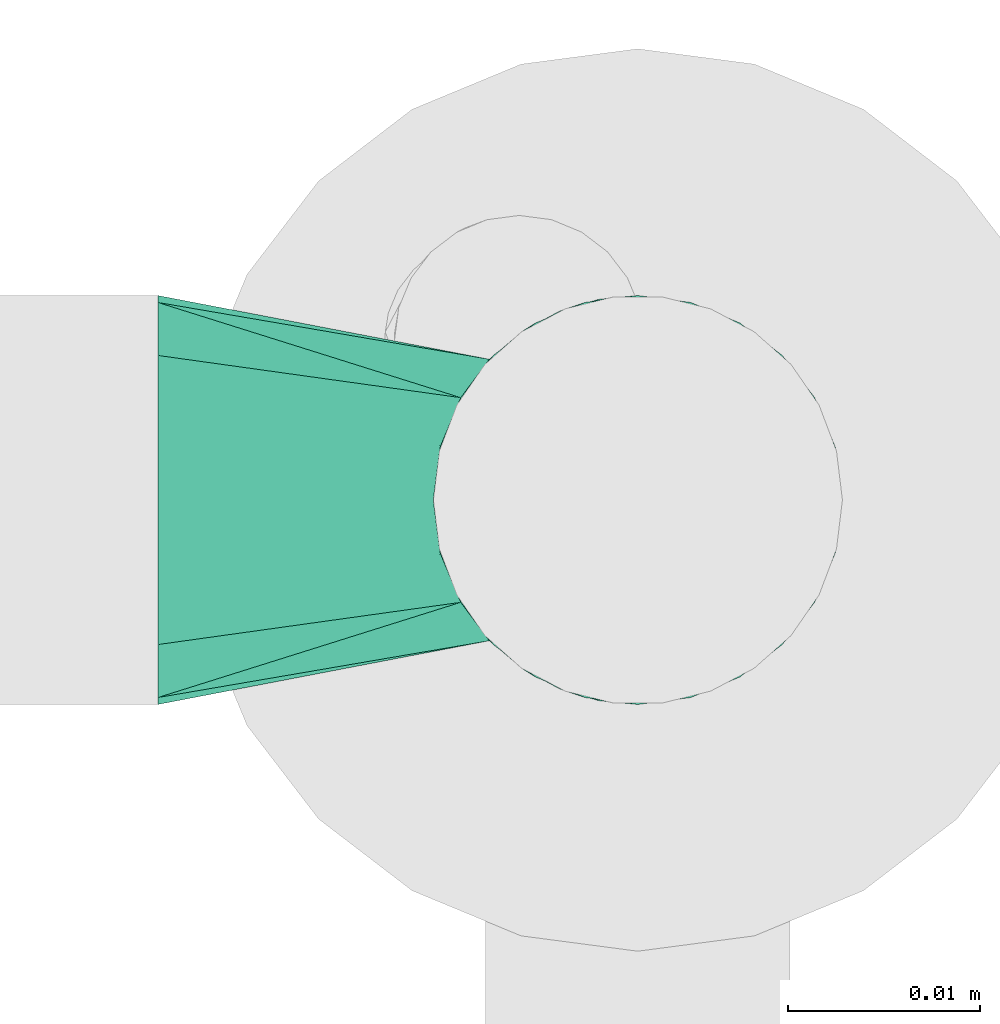
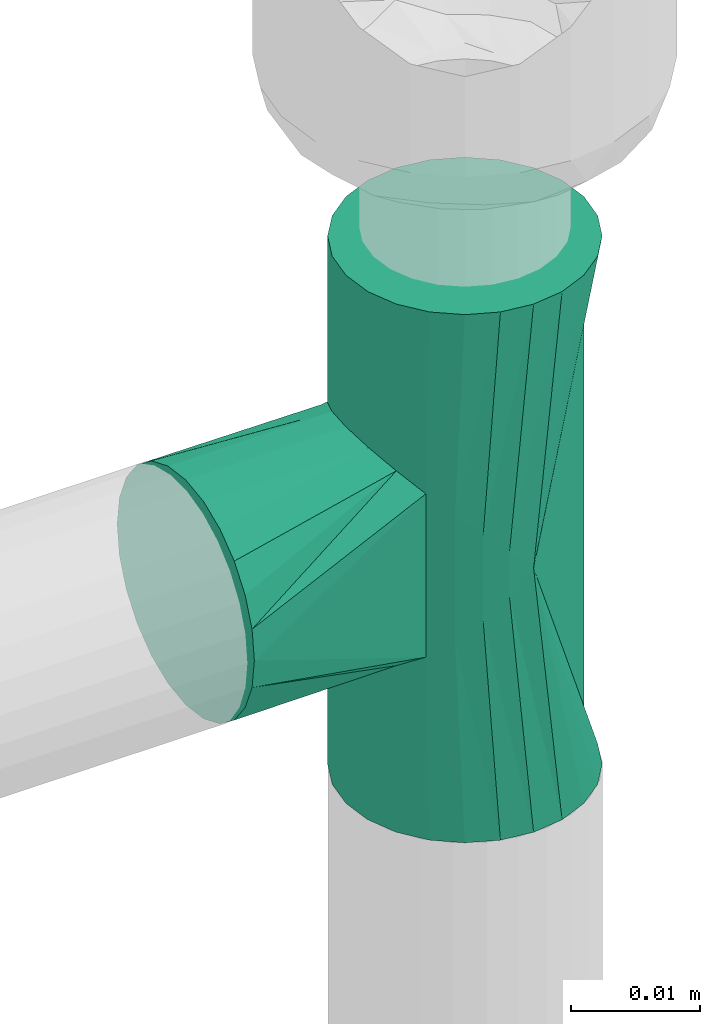
# One storey, part 819 of 827: 1 flow fitting.
"""IFC2X3 building model written with IfcOpenShell, lengths in millimetres."""

from ifc_helpers import new_model, entity, si_unit, converted_unit, derived_unit, direction, frame, origin, place, context, subcontext, project, spatial, faceted_brep, source, transform, mapped, material, type_object, type_shapes, element, save


model = new_model("IFC2X3")

# Units and contexts
model_context = context("Model", 3, precision=0.01, world=origin(), true_north=direction((6.12303176911189e-17, 1.0)))
body_context = subcontext(model_context, "Body", "Model", "MODEL_VIEW")
ifc_project = project(units=[si_unit("LENGTHUNIT", "METRE", prefix="MILLI"), si_unit("AREAUNIT", "SQUARE_METRE"), si_unit("VOLUMEUNIT", "CUBIC_METRE"), converted_unit("PLANEANGLEUNIT", "DEGREE", entity("IfcRatioMeasure", 0.0174532925199433), si_unit("PLANEANGLEUNIT", "RADIAN"), dimensions=[0, 0, 0, 0, 0, 0, 0]), si_unit("MASSUNIT", "GRAM", prefix="KILO"), derived_unit("MASSDENSITYUNIT", [(si_unit("MASSUNIT", "GRAM", prefix="KILO"), 1), (si_unit("LENGTHUNIT", "METRE"), -3)]), derived_unit("MOMENTOFINERTIAUNIT", [(si_unit("LENGTHUNIT", "METRE"), 4)]), si_unit("TIMEUNIT", "SECOND"), si_unit("FREQUENCYUNIT", "HERTZ"), si_unit("THERMODYNAMICTEMPERATUREUNIT", "DEGREE_CELSIUS"), derived_unit("THERMALTRANSMITTANCEUNIT", [(si_unit("MASSUNIT", "GRAM", prefix="KILO"), 1), (si_unit("THERMODYNAMICTEMPERATUREUNIT", "KELVIN"), -1), (si_unit("TIMEUNIT", "SECOND"), -3)]), derived_unit("VOLUMETRICFLOWRATEUNIT", [(si_unit("LENGTHUNIT", "METRE"), 3), (si_unit("TIMEUNIT", "SECOND"), -1)]), derived_unit("MASSFLOWRATEUNIT", [(si_unit("MASSUNIT", "GRAM", prefix="KILO"), 1), (si_unit("TIMEUNIT", "SECOND"), -1)]), derived_unit("ROTATIONALFREQUENCYUNIT", [(si_unit("TIMEUNIT", "SECOND"), -1)]), si_unit("ELECTRICCURRENTUNIT", "AMPERE"), si_unit("ELECTRICVOLTAGEUNIT", "VOLT"), si_unit("POWERUNIT", "WATT"), si_unit("FORCEUNIT", "NEWTON", prefix="KILO"), si_unit("ILLUMINANCEUNIT", "LUX"), si_unit("LUMINOUSFLUXUNIT", "LUMEN"), si_unit("LUMINOUSINTENSITYUNIT", "CANDELA"), derived_unit("USERDEFINED", [(si_unit("MASSUNIT", "GRAM", prefix="KILO"), -1), (si_unit("LENGTHUNIT", "METRE"), -2), (si_unit("TIMEUNIT", "SECOND"), 3), (si_unit("LUMINOUSFLUXUNIT", "LUMEN"), 1)]), derived_unit("LINEARVELOCITYUNIT", [(si_unit("LENGTHUNIT", "METRE"), 1), (si_unit("TIMEUNIT", "SECOND"), -1)]), si_unit("PRESSUREUNIT", "PASCAL"), derived_unit("USERDEFINED", [(si_unit("LENGTHUNIT", "METRE"), -2), (si_unit("MASSUNIT", "GRAM", prefix="KILO"), 1), (si_unit("TIMEUNIT", "SECOND"), -2)]), derived_unit("LINEARFORCEUNIT", [(si_unit("MASSUNIT", "GRAM", prefix="KILO"), 1), (si_unit("LENGTHUNIT", "METRE"), 1), (si_unit("TIMEUNIT", "SECOND"), -2), (si_unit("LENGTHUNIT", "METRE"), -1)]), derived_unit("PLANARFORCEUNIT", [(si_unit("MASSUNIT", "GRAM", prefix="KILO"), 1), (si_unit("LENGTHUNIT", "METRE"), 1), (si_unit("TIMEUNIT", "SECOND"), -2), (si_unit("LENGTHUNIT", "METRE"), -2)])], contexts=[model_context])

# Site, building, storey
site_placement = place(None, origin())
site = spatial("IfcSite", under=ifc_project, at=site_placement, CompositionType="ELEMENT")
building_placement = place(site_placement, origin())
building = spatial("IfcBuilding", under=site, at=building_placement, CompositionType="ELEMENT")
storey_placement = place(building_placement, frame((0.0, 0.0, 28200.0)))
storey = spatial("IfcBuildingStorey", under=building, at=storey_placement, Name="08", CompositionType="ELEMENT", Elevation=28200.0)

# Flow fitting
ifc_material = material()
pipe_fitting_type = type_object("IfcPipeFittingType", Name="ADSK_1", PredefinedType="NOTDEFINED", material=ifc_material)
shared_shape = source(origin(), body_context, "Body", "Brep", [
    faceted_brep([(-25.0, 0.0, -10.65), (-25.0, -2.76, -10.29), (-25.0, -5.32, -9.22), (-25.0, -7.53, -7.53), (-25.0, -9.22, -5.33), (-25.0, -10.29, -2.76), (-25.0, -10.65, 0.0), (-25.0, -10.29, 2.76), (-25.0, -9.22, 5.32), (-25.0, -7.53, 7.53), (-25.0, -5.32, 9.22), (-25.0, -2.76, 10.29), (-25.0, 0.0, 10.65), (-25.0, 2.76, 10.29), (-25.0, 5.33, 9.22), (-25.0, 7.53, 7.53), (-25.0, 9.22, 5.32), (-25.0, 10.29, 2.76), (-25.0, 10.65, 0.0), (-25.0, 10.29, -2.76), (-25.0, 9.22, -5.33), (-25.0, 7.53, -7.53), (-25.0, 5.33, -9.22), (-25.0, 2.76, -10.29), (25.0, -5.32, -9.22), (25.0, -2.76, -10.29), (25.0, 0.0, -10.65), (25.0, 2.76, -10.29), (25.0, 5.33, -9.22), (25.0, 7.53, -7.53), (25.0, 9.22, -5.33), (25.0, 10.29, -2.76), (25.0, 10.65, 0.0), (25.0, 10.29, 2.76), (25.0, 9.22, 5.32), (25.0, 7.53, 7.53), (25.0, 5.33, 9.22), (25.0, 2.76, 10.29), (25.0, 0.0, 10.65), (25.0, -2.76, 10.29), (25.0, -5.32, 9.22), (25.0, -7.53, 7.53), (25.0, -9.22, 5.32), (25.0, -10.29, 2.76), (25.0, -10.65, 0.0), (25.0, -10.29, -2.76), (25.0, -9.22, -5.33), (25.0, -7.53, -7.53), (10.65, 10.65, 0.0), (-10.65, 10.65, 0.0), (10.26, 10.26, 2.84), (9.22, 9.22, 5.33), (7.73, 7.73, 7.33), (5.97, 5.97, 8.82), (-10.26, 10.26, 2.84), (-9.22, 9.22, 5.33), (-5.97, 5.97, 8.82), (-7.73, 7.73, 7.33), (4.05, 4.05, 9.85), (2.05, 2.05, 10.45), (0.0, 0.0, 10.65), (-2.05, 2.05, 10.45), (-4.05, 4.05, 9.85), (0.0, 0.0, -10.65), (2.05, 2.05, -10.45), (4.05, 4.05, -9.85), (5.97, 5.97, -8.82), (-2.05, 2.05, -10.45), (-4.05, 4.05, -9.85), (7.73, 7.73, -7.33), (9.22, 9.22, -5.33), (10.26, 10.26, -2.84), (-5.97, 5.97, -8.82), (-7.73, 7.73, -7.33), (-9.22, 9.22, -5.33), (-10.26, 10.26, -2.84), (5.33, 25.0, -9.22), (2.76, 25.0, -10.29), (0.0, 25.0, -10.65), (-2.76, 25.0, -10.29), (-5.32, 25.0, -9.22), (-7.53, 25.0, -7.53), (-9.22, 25.0, -5.33), (-10.29, 25.0, -2.76), (-10.65, 25.0, 0.0), (-10.29, 25.0, 2.76), (-9.22, 25.0, 5.32), (-7.53, 25.0, 7.53), (-5.32, 25.0, 9.22), (-2.76, 25.0, 10.29), (0.0, 25.0, 10.65), (2.76, 25.0, 10.29), (5.33, 25.0, 9.22), (7.53, 25.0, 7.53), (9.22, 25.0, 5.32), (10.29, 25.0, 2.76), (10.65, 25.0, 0.0), (10.29, 25.0, -2.76), (9.22, 25.0, -5.33), (7.53, 25.0, -7.53)], [[[0, 1, 2, 3, 4, 5, 6, 7, 8, 9, 10, 11, 12, 13, 14, 15, 16, 17, 18, 19, 20, 21, 22, 23]], [[24, 25, 26, 27, 28, 29, 30, 31, 32, 33, 34, 35, 36, 37, 38, 39, 40, 41, 42, 43, 44, 45, 46, 47]], [[48, 33, 32]], [[18, 17, 49]], [[48, 50, 33]], [[34, 33, 50]], [[51, 34, 50]], [[52, 36, 35]], [[35, 51, 52]], [[36, 52, 53]], [[34, 51, 35]], [[17, 54, 49]], [[16, 54, 17]], [[16, 55, 54]], [[14, 56, 57]], [[55, 15, 57]], [[14, 57, 15]], [[16, 15, 55]], [[13, 56, 14]], [[36, 53, 37]], [[58, 38, 37]], [[58, 59, 38]], [[39, 38, 59]], [[39, 59, 60]], [[53, 58, 37]], [[60, 41, 40]], [[43, 42, 60]], [[41, 60, 42]], [[60, 40, 39]], [[44, 43, 60]], [[11, 61, 12]], [[13, 12, 62]], [[61, 62, 12]], [[56, 13, 62]], [[11, 60, 61]], [[8, 7, 60]], [[60, 9, 8]], [[60, 11, 10]], [[10, 9, 60]], [[6, 60, 7]], [[6, 44, 60]], [[44, 63, 45]], [[46, 63, 47]], [[46, 45, 63]], [[24, 47, 63]], [[64, 26, 25]], [[64, 65, 26]], [[27, 26, 65]], [[66, 27, 65]], [[63, 25, 24]], [[25, 63, 64]], [[3, 2, 63]], [[4, 63, 5]], [[63, 4, 3]], [[6, 5, 63]], [[1, 67, 63]], [[1, 0, 67]], [[68, 0, 23]], [[67, 0, 68]], [[2, 1, 63]], [[63, 44, 6]], [[69, 29, 28]], [[28, 66, 69]], [[29, 69, 70]], [[70, 30, 29]], [[71, 31, 30]], [[71, 48, 31]], [[32, 31, 48]], [[18, 49, 19]], [[70, 71, 30]], [[23, 22, 72]], [[21, 73, 22]], [[72, 22, 73]], [[74, 73, 21]], [[68, 23, 72]], [[19, 49, 75]], [[20, 75, 74]], [[20, 19, 75]], [[21, 20, 74]], [[28, 27, 66]], [[76, 77, 78, 79, 80, 81, 82, 83, 84, 85, 86, 87, 88, 89, 90, 91, 92, 93, 94, 95, 96, 97, 98, 99]], [[84, 49, 85]], [[85, 54, 86]], [[88, 87, 55]], [[55, 89, 88]], [[54, 87, 86]], [[89, 57, 90]], [[85, 49, 54]], [[87, 54, 55]], [[57, 56, 53, 52]], [[62, 61, 59, 58]], [[53, 56, 62, 58]], [[57, 89, 55]], [[57, 52, 90]], [[91, 51, 92]], [[92, 51, 93]], [[95, 94, 50]], [[95, 48, 96]], [[50, 94, 93]], [[48, 95, 50]], [[59, 61, 60]], [[93, 51, 50]], [[91, 52, 51]], [[91, 90, 52]], [[96, 48, 97]], [[97, 71, 98]], [[76, 99, 70]], [[70, 77, 76]], [[71, 99, 98]], [[77, 69, 78]], [[97, 48, 71]], [[99, 71, 70]], [[69, 66, 72, 73]], [[65, 64, 67, 68]], [[72, 66, 65, 68]], [[69, 77, 70]], [[69, 73, 78]], [[79, 74, 80]], [[80, 74, 81]], [[83, 82, 75]], [[83, 49, 84]], [[75, 82, 81]], [[49, 83, 75]], [[67, 64, 63]], [[81, 74, 75]], [[79, 73, 74]], [[79, 78, 73]]]),
])
type_shapes(pipe_fitting_type, [shared_shape])
flow_fitting_placement = place(storey_placement, frame((26355.85, 16041.72, 3130.0), z_axis=(0.0, -1.0, 0.0), x_axis=(0.0, 0.0, 1.0)))
element("IfcFlowFitting", 1, at=flow_fitting_placement, inside=storey, type_object=pipe_fitting_type, material=ifc_material, Name="ADSK_1", ObjectType="ADSK_1", context=body_context, shape_type="MappedRepresentation", body=[
    mapped(shared_shape, transform((0.0, 0.0, 0.0), scale=1.0)),
])

save(model, "model.ifc")
